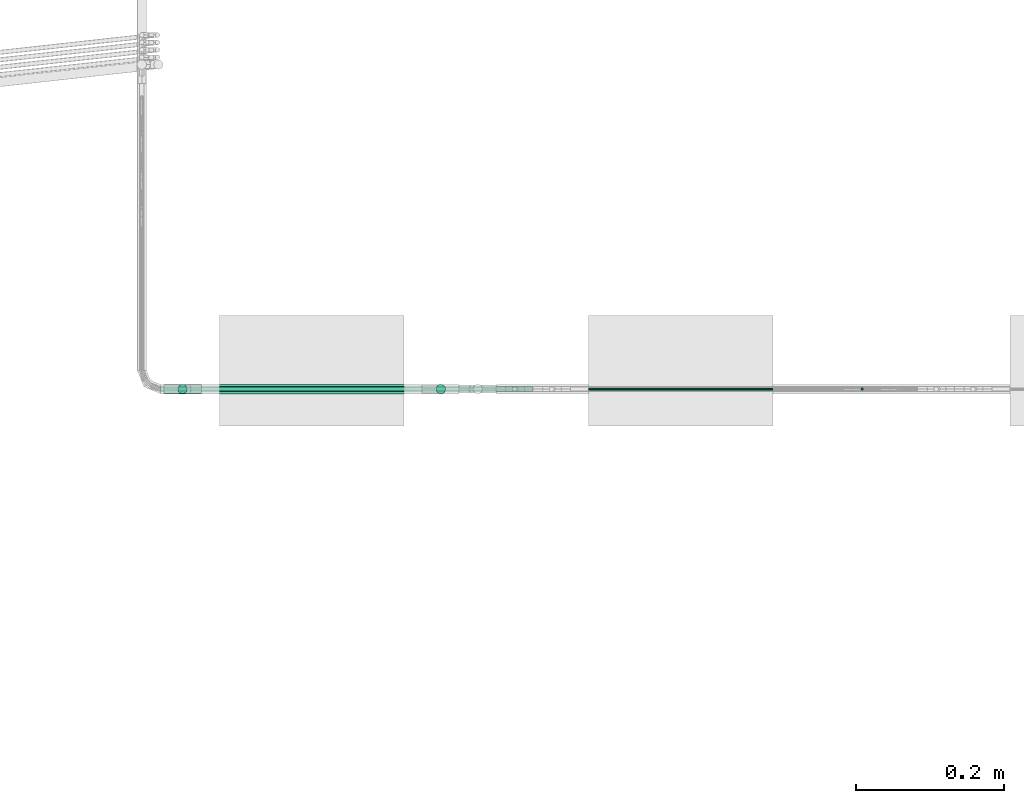
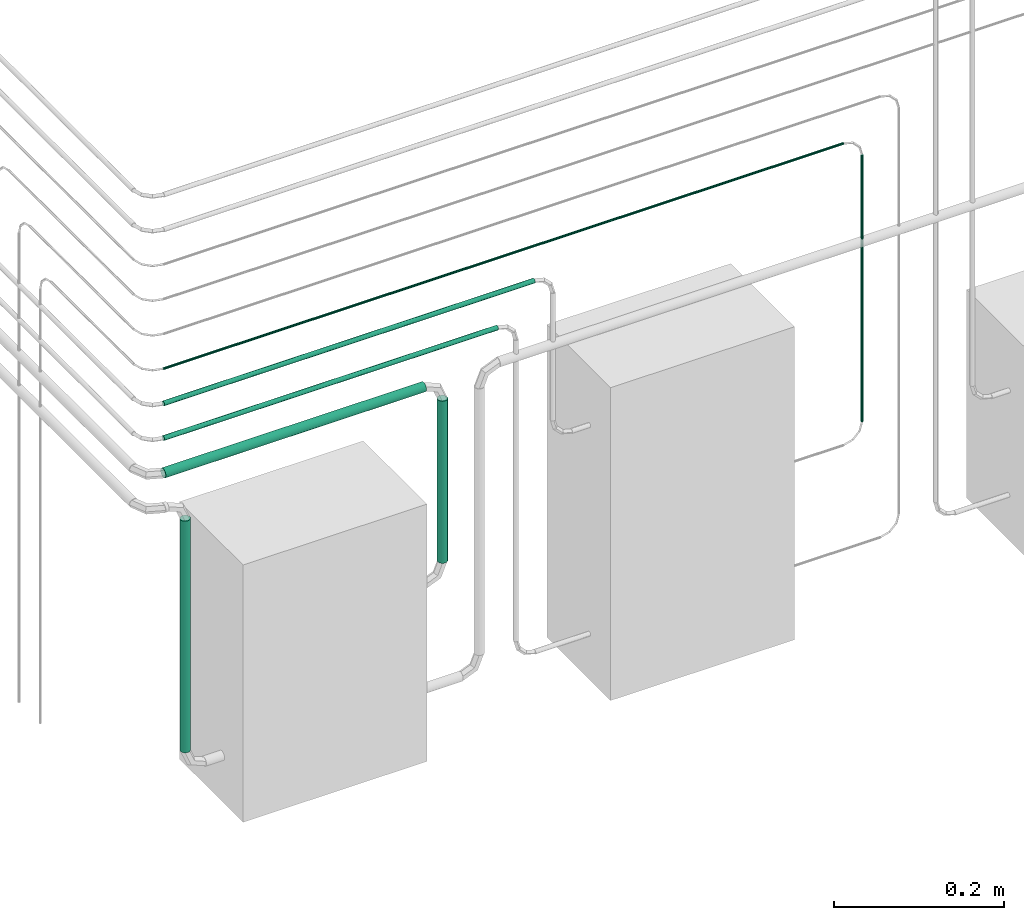
# One storey, part 23 of 45: 7 flow segments.
"""IFC2X3 building model written with IfcOpenShell, lengths in millimetres."""

import ifcopenshell
import ifcopenshell.guid

model = None  # the IFC model being written
_history = None  # IfcOwnerHistory: only IFC2X3 demands one
_inside = {}  # id of a spatial element -> (the spatial element, [elements in it])
_under = {}  # id of a project, library or spatial element -> (it, [spatial elements below it])
_declared = {}  # id of a project -> (the project, [libraries it declares])
_typed = {}  # id of a type object -> (the type object, [elements of that type])
_made_of = {}  # id of a material, layer set ... -> (it, [elements and type objects made of it])


def new_model(schema):
    """Start an empty IFC model of exactly this schema.

    Asked for "IFC4X3", IfcOpenShell would pick the latest addendum, in which some entities
    have other attributes; the version numbers below select the first issue.
    IFC2X3 requires an IfcOwnerHistory on every rooted entity: one is made here for all.
    """
    global model, _history
    if schema == "IFC4X3":
        model = ifcopenshell.file(schema_version=(4, 3, 0, 0))
    else:
        model = ifcopenshell.file(schema=schema)
    _inside.clear()
    _under.clear()
    _declared.clear()
    _typed.clear()
    _made_of.clear()
    _history = None
    if model.schema == "IFC2X3":
        org = make("IfcOrganization", Name="unknown")
        user = make(
            "IfcPersonAndOrganization",
            ThePerson=make("IfcPerson", FamilyName="unknown"),
            TheOrganization=org,
        )
        app = make(
            "IfcApplication",
            ApplicationDeveloper=org,
            Version="unknown",
            ApplicationFullName="unknown",
            ApplicationIdentifier="unknown",
        )
        _history = make(
            "IfcOwnerHistory",
            OwningUser=user,
            OwningApplication=app,
            ChangeAction="ADDED",
            CreationDate=0,
        )
    return model


def make(cls, **values):
    """One entity of the class cls with the attributes given. An attribute that is None is left unset."""
    return model.create_entity(
        cls, **{name: value for name, value in values.items() if value is not None}
    )


def entity(cls, *values):
    """Any entity or typed value of the class cls, its attributes in the order of the schema. None: left unset."""
    e = model.create_entity(cls)
    for i, value in enumerate(values):
        if value is not None:
            e[i] = value
    return e


def rooted(cls, **values):
    """An entity with a GlobalId (a new one), such as an element, a storey or a relation."""
    return make(cls, GlobalId=ifcopenshell.guid.new(), OwnerHistory=_history, **values)


def si_unit(unit_type, name, prefix=None):
    """IfcSIUnit, for example si_unit("LENGTHUNIT", "METRE", prefix="MILLI")."""
    return make("IfcSIUnit", UnitType=unit_type, Prefix=prefix, Name=name)


def converted_unit(unit_type, name, factor, base, dimensions=None, offset=None):
    """IfcConversionBasedUnit, such as the inch: factor (a typed value) times the base unit."""
    return make(
        "IfcConversionBasedUnit"
        if offset is None
        else "IfcConversionBasedUnitWithOffset",
        ConversionOffset=offset,
        Dimensions=None
        if dimensions is None
        else entity("IfcDimensionalExponents", *dimensions),
        UnitType=unit_type,
        Name=name,
        ConversionFactor=make(
            "IfcMeasureWithUnit", ValueComponent=factor, UnitComponent=base
        ),
    )


def derived_unit(unit_type, elements):
    """IfcDerivedUnit: a product of units, each with its exponent."""
    return make(
        "IfcDerivedUnit",
        Elements=[
            make("IfcDerivedUnitElement", Unit=unit, Exponent=power)
            for unit, power in elements
        ],
        UnitType=unit_type,
    )


def assignment(units):
    """IfcUnitAssignment: the units of a project."""
    return None if units is None else make("IfcUnitAssignment", Units=units)


def point(xyz):
    """IfcCartesianPoint."""
    return None if xyz is None else make("IfcCartesianPoint", Coordinates=xyz)


def direction(xyz):
    """IfcDirection."""
    return None if xyz is None else make("IfcDirection", DirectionRatios=xyz)


def frame(location, z_axis=None, x_axis=None):
    """IfcAxis2Placement3D, a coordinate frame: its origin and axes. An axis left out is left unset."""
    return make(
        "IfcAxis2Placement3D",
        Location=point(location),
        Axis=direction(z_axis),
        RefDirection=direction(x_axis),
    )


def frame_2d(location, x_axis=None):
    """IfcAxis2Placement2D, a coordinate frame in the plane: its origin and x axis."""
    return make(
        "IfcAxis2Placement2D", Location=point(location), RefDirection=direction(x_axis)
    )


def origin():
    """The frame at (0, 0, 0) with its axes left unset."""
    return frame((0.0, 0.0, 0.0))


def origin_2d_with_axis():
    """The frame at (0, 0) in the plane with the x axis (1, 0) written out."""
    return frame_2d((0.0, 0.0), x_axis=(1.0, 0.0))


def place(relative_to, where):
    """IfcLocalPlacement: puts the frame where relative to a parent placement (None: the world)."""
    return make(
        "IfcLocalPlacement", PlacementRelTo=relative_to, RelativePlacement=where
    )


def context(
    kind, dimensions, precision=None, world=None, true_north=None, identifier=None
):
    """IfcGeometricRepresentationContext, for example the 3D "Model" context."""
    return make(
        "IfcGeometricRepresentationContext",
        ContextIdentifier=identifier,
        ContextType=kind,
        CoordinateSpaceDimension=dimensions,
        Precision=precision,
        WorldCoordinateSystem=world,
        TrueNorth=true_north,
    )


def subcontext(parent, identifier, kind, view, scale=None):
    """IfcGeometricRepresentationSubContext, for example "Body" below "Model"."""
    return make(
        "IfcGeometricRepresentationSubContext",
        ContextIdentifier=identifier,
        ContextType=kind,
        ParentContext=parent,
        TargetScale=scale,
        TargetView=view,
    )


def project(units=None, contexts=None):
    """IfcProject with its units and contexts."""
    return rooted(
        "IfcProject",
        Name="project",
        RepresentationContexts=contexts,
        UnitsInContext=assignment(units),
    )


def spatial(cls, under=None, at=None, **own):
    """A site, building, storey or space (cls), placed at a placement, below another one or the project."""
    s = rooted(cls, ObjectPlacement=at, **own)
    if under is not None:
        _under.setdefault(under.id(), (under, []))[1].append(s)
    return s


def profile(cls, at=None, kind="AREA", **sizes):
    """A parametric profile (cls). Its sizes go by their IFC names, for example OverallWidth=200.0."""
    return make(cls, ProfileType=kind, Position=at, **sizes)


def circle(**sizes):
    """IfcCircleProfileDef."""
    return profile("IfcCircleProfileDef", **sizes)


def extrude(swept, where, along, depth):
    """IfcExtrudedAreaSolid: the profile swept, set in the frame where, extruded along a direction by depth."""
    return make(
        "IfcExtrudedAreaSolid",
        SweptArea=swept,
        Position=where,
        ExtrudedDirection=direction(along),
        Depth=depth,
    )


def shape(context_of_items, identifier, shape_type, items):
    """IfcShapeRepresentation: the items that make up one representation, for example the "Body"."""
    return make(
        "IfcShapeRepresentation",
        ContextOfItems=context_of_items,
        RepresentationIdentifier=identifier,
        RepresentationType=shape_type,
        Items=items,
    )


def made_of(thing, what):
    """Note that an element or type object is made of a material, layer set ...; save() writes the relation."""
    if what is not None:
        _made_of.setdefault(what.id(), (what, []))[1].append(thing)
    return thing


def type_object(cls, material=None, **own):
    """A type object (cls), such as IfcWallType, which elements share."""
    return made_of(rooted(cls, **own), material)


def element(
    cls,
    number,
    at=None,
    inside=None,
    cuts=None,
    type_object=None,
    material=None,
    context=None,
    identifier="Body",
    shape_type=None,
    held_by="IfcProductDefinitionShape",
    body=None,
    shapes=None,
    **own,
):
    """One element of the class cls, such as IfcWall. Its Tag is "e" and its number.

    at: its placement. inside: the storey or other place that contains it. cuts: it is an
    opening in that element (IfcRelVoidsElement). A single representation is given by context,
    identifier, shape_type and body (its items); several are given by shapes. held_by: the class
    of the entity that holds the representations. save() writes the other relations.
    """
    e = rooted(cls, Tag="e%d" % number, ObjectPlacement=at, **own)
    if body is not None:
        shapes = [shape(context, identifier, shape_type, body)]
    if shapes is not None:
        e.Representation = make(held_by, Representations=shapes)
    if inside is not None:
        _inside.setdefault(inside.id(), (inside, []))[1].append(e)
    if cuts is not None:
        rooted(
            "IfcRelVoidsElement", RelatingBuildingElement=cuts, RelatedOpeningElement=e
        )
    if type_object is not None:
        _typed.setdefault(type_object.id(), (type_object, []))[1].append(e)
    return made_of(e, material)


def aggregate(whole, parts):
    """IfcRelAggregates: a whole, such as a stair, and the parts it consists of."""
    return rooted("IfcRelAggregates", RelatingObject=whole, RelatedObjects=parts)


def save(model, path):
    """Write the relations noted so far, then the file.

    IfcRelAggregates (storeys below a building ...), IfcRelContainedInSpatialStructure (elements
    in a storey), IfcRelDefinesByType, IfcRelAssociatesMaterial and IfcRelDeclares: one each for
    every whole, place, type object, material and project.
    """
    for whole, parts in _under.values():
        aggregate(whole, parts)
    for where, things in _inside.values():
        rooted(
            "IfcRelContainedInSpatialStructure",
            RelatedElements=things,
            RelatingStructure=where,
        )
    for kind, things in _typed.values():
        rooted("IfcRelDefinesByType", RelatedObjects=things, RelatingType=kind)
    for what, things in _made_of.values():
        rooted("IfcRelAssociatesMaterial", RelatedObjects=things, RelatingMaterial=what)
    for by, libraries in _declared.values():
        rooted("IfcRelDeclares", RelatingContext=by, RelatedDefinitions=libraries)
    model.write(path)


model = new_model("IFC2X3")

# Units and contexts
model_context = context("Model", 3, precision=0.01, world=origin(), true_north=direction((6.12303176911189e-17, 1.0)))
body_context = subcontext(model_context, "Body", "Model", "MODEL_VIEW")
ifc_project = project(units=[si_unit("LENGTHUNIT", "METRE", prefix="MILLI"), si_unit("AREAUNIT", "SQUARE_METRE"), si_unit("VOLUMEUNIT", "CUBIC_METRE"), converted_unit("PLANEANGLEUNIT", "DEGREE", entity("IfcRatioMeasure", 0.0174532925199433), si_unit("PLANEANGLEUNIT", "RADIAN"), dimensions=[0, 0, 0, 0, 0, 0, 0]), si_unit("MASSUNIT", "GRAM", prefix="KILO"), derived_unit("MASSDENSITYUNIT", [(si_unit("MASSUNIT", "GRAM", prefix="KILO"), 1), (si_unit("LENGTHUNIT", "METRE"), -3)]), derived_unit("MOMENTOFINERTIAUNIT", [(si_unit("LENGTHUNIT", "METRE"), 4)]), si_unit("TIMEUNIT", "SECOND"), si_unit("FREQUENCYUNIT", "HERTZ"), si_unit("THERMODYNAMICTEMPERATUREUNIT", "DEGREE_CELSIUS"), derived_unit("THERMALTRANSMITTANCEUNIT", [(si_unit("MASSUNIT", "GRAM", prefix="KILO"), 1), (si_unit("THERMODYNAMICTEMPERATUREUNIT", "KELVIN"), -1), (si_unit("TIMEUNIT", "SECOND"), -3)]), derived_unit("VOLUMETRICFLOWRATEUNIT", [(si_unit("LENGTHUNIT", "METRE"), 3), (si_unit("TIMEUNIT", "SECOND"), -1)]), derived_unit("MASSFLOWRATEUNIT", [(si_unit("MASSUNIT", "GRAM", prefix="KILO"), 1), (si_unit("TIMEUNIT", "SECOND"), -1)]), derived_unit("ROTATIONALFREQUENCYUNIT", [(si_unit("TIMEUNIT", "SECOND"), -1)]), si_unit("ELECTRICCURRENTUNIT", "AMPERE"), si_unit("ELECTRICVOLTAGEUNIT", "VOLT"), si_unit("POWERUNIT", "WATT"), si_unit("FORCEUNIT", "NEWTON", prefix="KILO"), si_unit("ILLUMINANCEUNIT", "LUX"), si_unit("LUMINOUSFLUXUNIT", "LUMEN"), si_unit("LUMINOUSINTENSITYUNIT", "CANDELA"), derived_unit("USERDEFINED", [(si_unit("MASSUNIT", "GRAM", prefix="KILO"), -1), (si_unit("LENGTHUNIT", "METRE"), -2), (si_unit("TIMEUNIT", "SECOND"), 3), (si_unit("LUMINOUSFLUXUNIT", "LUMEN"), 1)]), derived_unit("LINEARVELOCITYUNIT", [(si_unit("LENGTHUNIT", "METRE"), 1), (si_unit("TIMEUNIT", "SECOND"), -1)]), si_unit("PRESSUREUNIT", "PASCAL"), derived_unit("USERDEFINED", [(si_unit("LENGTHUNIT", "METRE"), -2), (si_unit("MASSUNIT", "GRAM", prefix="KILO"), 1), (si_unit("TIMEUNIT", "SECOND"), -2)]), derived_unit("LINEARFORCEUNIT", [(si_unit("MASSUNIT", "GRAM", prefix="KILO"), 1), (si_unit("LENGTHUNIT", "METRE"), 1), (si_unit("TIMEUNIT", "SECOND"), -2), (si_unit("LENGTHUNIT", "METRE"), -1)]), derived_unit("PLANARFORCEUNIT", [(si_unit("MASSUNIT", "GRAM", prefix="KILO"), 1), (si_unit("LENGTHUNIT", "METRE"), 1), (si_unit("TIMEUNIT", "SECOND"), -2), (si_unit("LENGTHUNIT", "METRE"), -2)])], contexts=[model_context])

# Site, building, storey
site_placement = place(None, frame((-24836.06, 8968.75, 0.0)))
site = spatial("IfcSite", under=ifc_project, at=site_placement, CompositionType="ELEMENT")
building_placement = place(site_placement, origin())
building = spatial("IfcBuilding", under=site, at=building_placement, CompositionType="ELEMENT")
storey_placement = place(building_placement, frame((0.0, 0.0, -4200.0)))
storey = spatial("IfcBuildingStorey", under=building, at=storey_placement, CompositionType="ELEMENT", Elevation=-4200.0)

# Flow segments
pipe_segment_type = type_object("IfcPipeSegmentType", PredefinedType="NOTDEFINED")
flow_segment_1_placement = place(storey_placement, frame((81718.54, -7591.94, 1741.46)))
element("IfcFlowSegment", 1, at=flow_segment_1_placement, inside=storey, type_object=pipe_segment_type, context=body_context, shape_type="SweptSolid", body=[
    extrude(circle(Radius=1.59, at=origin_2d_with_axis()), frame((3.19, 3.19, 0.0), z_axis=(0.0, 0.0, 1.0), x_axis=(-1.0, 0.0, 0.0)), (0.0, 0.0, 1.0), 383.138220786862),
])
flow_segment_2_placement = place(storey_placement, frame((80771.15, -7591.94, 2146.81)))
element("IfcFlowSegment", 2, at=flow_segment_2_placement, inside=storey, type_object=pipe_segment_type, context=body_context, shape_type="SweptSolid", body=[
    extrude(circle(Radius=1.59, at=origin_2d_with_axis()), frame((0.0, 3.19, 3.19), z_axis=(1.0, 0.0, 0.0), x_axis=(0.0, 1.0, 0.0)), (0.0, 0.0, 1.0), 925.169523837461),
])
flow_segment_3_placement = place(storey_placement, frame((81142.97, -7596.7, 1741.46)))
element("IfcFlowSegment", 3, at=flow_segment_3_placement, inside=storey, type_object=pipe_segment_type, context=body_context, shape_type="SweptSolid", body=[
    extrude(circle(Radius=6.35, at=origin_2d_with_axis()), frame((7.95, 7.95, 0.0), z_axis=(0.0, 0.0, 1.0), x_axis=(-1.0, 0.0, 0.0)), (0.0, 0.0, 1.0), 233.138220786858),
])
flow_segment_4_placement = place(storey_placement, frame((80771.15, -7596.7, 1992.05)))
element("IfcFlowSegment", 4, at=flow_segment_4_placement, inside=storey, type_object=pipe_segment_type, context=body_context, shape_type="SweptSolid", body=[
    extrude(circle(Radius=6.35, at=origin_2d_with_axis()), frame((0.0, 7.95, 7.95), z_axis=(1.0, 0.0, 0.0), x_axis=(0.0, 1.0, 0.0)), (0.0, 0.0, 1.0), 354.365444248871),
])
flow_segment_5_placement = place(storey_placement, frame((80792.97, -7596.7, 1591.46)))
element("IfcFlowSegment", 5, at=flow_segment_5_placement, inside=storey, type_object=pipe_segment_type, context=body_context, shape_type="SweptSolid", body=[
    extrude(circle(Radius=6.35, at=origin_2d_with_axis()), frame((7.95, 7.95, 0.0)), (0.0, 0.0, 1.0), 333.138220786847),
])
flow_segment_6_placement = place(storey_placement, frame((80771.15, -7593.52, 2045.23)))
element("IfcFlowSegment", 6, at=flow_segment_6_placement, inside=storey, type_object=pipe_segment_type, context=body_context, shape_type="SweptSolid", body=[
    extrude(circle(Radius=3.175, at=origin_2d_with_axis()), frame((0.0, 4.77, 4.77), z_axis=(1.0, 0.0, 0.0), x_axis=(0.0, 1.0, 0.0)), (0.0, 0.0, 1.0), 454.22825500752),
])
flow_segment_7_placement = place(storey_placement, frame((80771.15, -7593.52, 2095.23)))
element("IfcFlowSegment", 7, at=flow_segment_7_placement, inside=storey, type_object=pipe_segment_type, context=body_context, shape_type="SweptSolid", body=[
    extrude(circle(Radius=3.175, at=origin_2d_with_axis()), frame((0.0, 4.77, 4.77), z_axis=(1.0, 0.0, 0.0), x_axis=(0.0, -1.0, 0.0)), (0.0, 0.0, 1.0), 504.228255007526),
])

save(model, "model.ifc")
